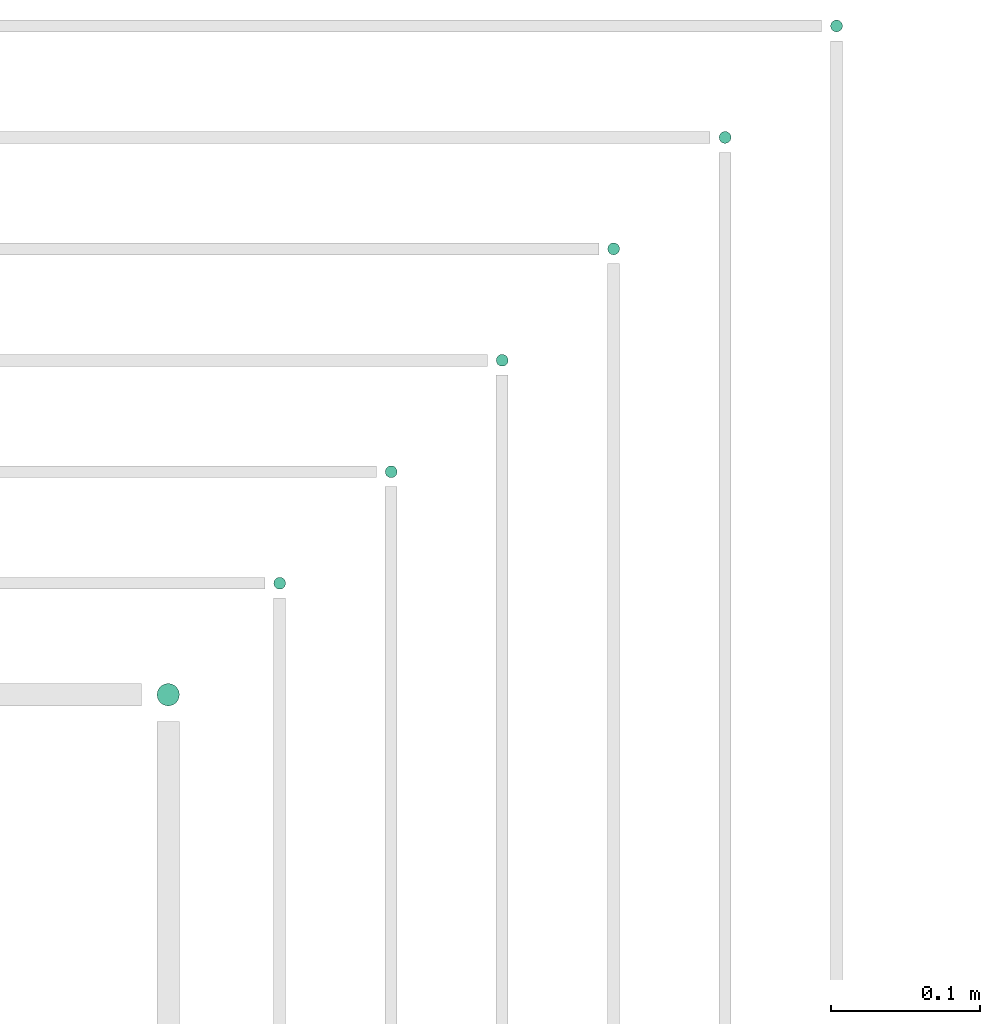
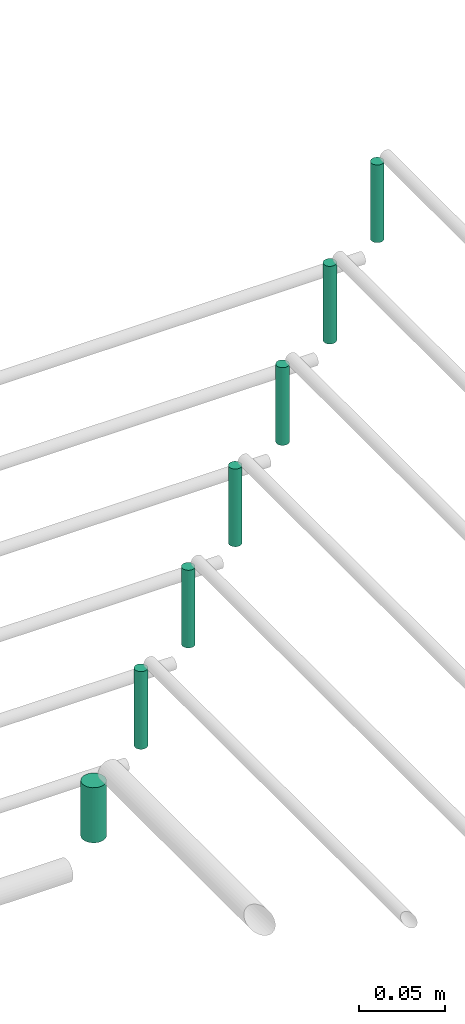
# One storey, part 89 of 89: 7 flow segments.
"""IFC2X3 building model written with IfcOpenShell, lengths in millimetres."""

from ifc_helpers import new_model, entity, si_unit, converted_unit, derived_unit, direction, frame, frame_2d, origin, origin_2d_with_axis, place, context, subcontext, project, spatial, circle, extrude, type_object, element, save


model = new_model("IFC2X3")

# Units and contexts
model_context = context("Model", 3, precision=0.01, world=origin(), true_north=direction((6.12303176911189e-17, 1.0)))
body_context = subcontext(model_context, "Body", "Model", "MODEL_VIEW")
ifc_project = project(units=[si_unit("LENGTHUNIT", "METRE", prefix="MILLI"), si_unit("AREAUNIT", "SQUARE_METRE"), si_unit("VOLUMEUNIT", "CUBIC_METRE"), converted_unit("PLANEANGLEUNIT", "DEGREE", entity("IfcRatioMeasure", 0.0174532925199433), si_unit("PLANEANGLEUNIT", "RADIAN"), dimensions=[0, 0, 0, 0, 0, 0, 0]), si_unit("MASSUNIT", "GRAM", prefix="KILO"), derived_unit("MASSDENSITYUNIT", [(si_unit("MASSUNIT", "GRAM", prefix="KILO"), 1), (si_unit("LENGTHUNIT", "METRE"), -3)]), derived_unit("MOMENTOFINERTIAUNIT", [(si_unit("LENGTHUNIT", "METRE"), 4)]), si_unit("TIMEUNIT", "SECOND"), si_unit("FREQUENCYUNIT", "HERTZ"), si_unit("THERMODYNAMICTEMPERATUREUNIT", "DEGREE_CELSIUS"), derived_unit("THERMALTRANSMITTANCEUNIT", [(si_unit("MASSUNIT", "GRAM", prefix="KILO"), 1), (si_unit("THERMODYNAMICTEMPERATUREUNIT", "KELVIN"), -1), (si_unit("TIMEUNIT", "SECOND"), -3)]), derived_unit("VOLUMETRICFLOWRATEUNIT", [(si_unit("LENGTHUNIT", "METRE"), 3), (si_unit("TIMEUNIT", "SECOND"), -1)]), derived_unit("MASSFLOWRATEUNIT", [(si_unit("MASSUNIT", "GRAM", prefix="KILO"), 1), (si_unit("TIMEUNIT", "SECOND"), -1)]), derived_unit("ROTATIONALFREQUENCYUNIT", [(si_unit("TIMEUNIT", "SECOND"), -1)]), si_unit("ELECTRICCURRENTUNIT", "AMPERE"), si_unit("ELECTRICVOLTAGEUNIT", "VOLT"), si_unit("POWERUNIT", "WATT"), si_unit("FORCEUNIT", "NEWTON", prefix="KILO"), si_unit("ILLUMINANCEUNIT", "LUX"), si_unit("LUMINOUSFLUXUNIT", "LUMEN"), si_unit("LUMINOUSINTENSITYUNIT", "CANDELA"), derived_unit("USERDEFINED", [(si_unit("MASSUNIT", "GRAM", prefix="KILO"), -1), (si_unit("LENGTHUNIT", "METRE"), -2), (si_unit("TIMEUNIT", "SECOND"), 3), (si_unit("LUMINOUSFLUXUNIT", "LUMEN"), 1)]), derived_unit("LINEARVELOCITYUNIT", [(si_unit("LENGTHUNIT", "METRE"), 1), (si_unit("TIMEUNIT", "SECOND"), -1)]), si_unit("PRESSUREUNIT", "PASCAL"), derived_unit("USERDEFINED", [(si_unit("LENGTHUNIT", "METRE"), -2), (si_unit("MASSUNIT", "GRAM", prefix="KILO"), 1), (si_unit("TIMEUNIT", "SECOND"), -2)]), derived_unit("LINEARFORCEUNIT", [(si_unit("MASSUNIT", "GRAM", prefix="KILO"), 1), (si_unit("LENGTHUNIT", "METRE"), 1), (si_unit("TIMEUNIT", "SECOND"), -2), (si_unit("LENGTHUNIT", "METRE"), -1)]), derived_unit("PLANARFORCEUNIT", [(si_unit("MASSUNIT", "GRAM", prefix="KILO"), 1), (si_unit("LENGTHUNIT", "METRE"), 1), (si_unit("TIMEUNIT", "SECOND"), -2), (si_unit("LENGTHUNIT", "METRE"), -2)])], contexts=[model_context])

# Site, building, storey
site_placement = place(None, frame((0.0, -0.00077364408347762, 0.0)))
site = spatial("IfcSite", under=ifc_project, at=site_placement, CompositionType="ELEMENT")
building_placement = place(site_placement, origin())
building = spatial("IfcBuilding", under=site, at=building_placement, CompositionType="ELEMENT")
storey_placement = place(building_placement, frame((0.0, 0.0, 24000.0)))
storey = spatial("IfcBuildingStorey", under=building, at=storey_placement, CompositionType="ELEMENT", Elevation=24000.0)

# Flow segments
pipe_segment_type = type_object("IfcPipeSegmentType", PredefinedType="NOTDEFINED")
for number, where in (
    (1, (64984.2044210321, 19094.4047277642, 2785.0)),
    (2, (64909.2044210321, 19019.4047277642, 2785.0)),
    (3, (64834.2044210321, 18944.4047277642, 2785.0)),
    (4, (64759.2044210321, 18869.4047277642, 2785.0)),
    (5, (64684.4898186752, 18794.4047277642, 2785.0)),
    (6, (64609.4898186752, 18719.4047277642, 2785.0)),
):
    element("IfcFlowSegment", number, at=place(storey_placement, frame(where)), inside=storey, type_object=pipe_segment_type, context=body_context, shape_type="SweptSolid", body=[
        extrude(circle(Radius=4.0, at=origin_2d_with_axis()), frame((5.59527223591499, 5.59527223591499, 0.0), z_axis=(0.0, 0.0, 1.0), x_axis=(-1.0, 0.0, 0.0)), (0.0, 0.0, 1.0), 55.0000000000135),
    ])
flow_segment_placement = place(storey_placement, frame((64530.9898186752, 18640.9047277642, 2793.0)))
element("IfcFlowSegment", 7, at=flow_segment_placement, inside=storey, type_object=pipe_segment_type, context=body_context, shape_type="SweptSolid", body=[
    extrude(circle(Radius=7.5, at=frame_2d((0.0, -2.16573425859679e-12), x_axis=(1.0, 0.0))), frame((9.09527223591419, 9.09527223591419, 0.0), z_axis=(0.0, 0.0, 1.0), x_axis=(-1.0, 0.0, 0.0)), (0.0, 0.0, 1.0), 39.0000000000171),
])

save(model, "model.ifc")
